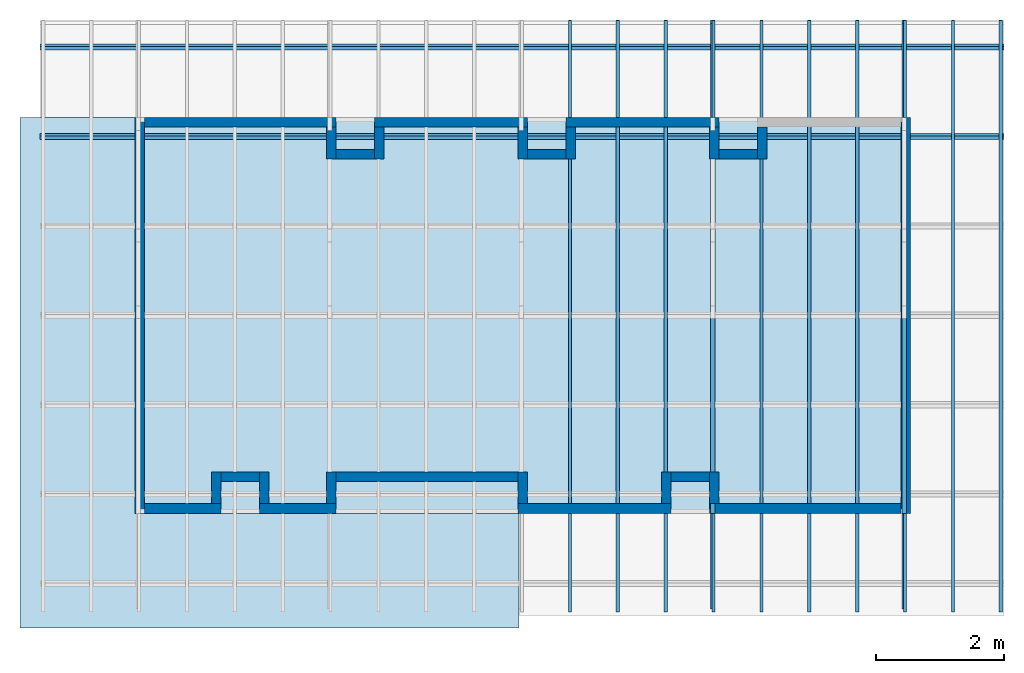
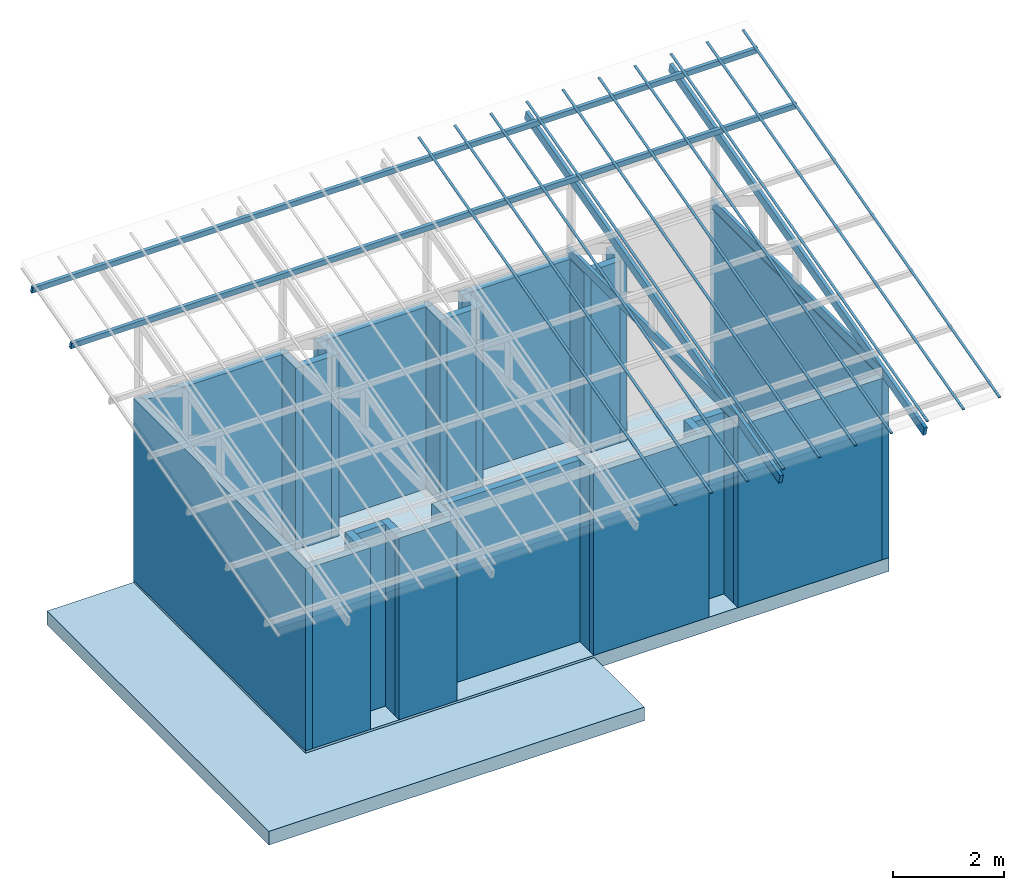
# One storey, part 2 of 4: 27 walls, 16 beams, 2 slabs.
"""IFC4 building model written with IfcOpenShell, lengths in metres."""

from ifc_helpers import new_model, entity, si_unit, converted_unit, frame, origin_with_axes, origin_2d_with_axis, place, context, subcontext, project, spatial, line, indexed_curve, rectangle, outline, extrude, material, layer, layer_set, layer_usage, material_profile, profile_set, profile_usage, type_object, element, save


model = new_model("IFC4")

# Units and contexts
model_context = context("Model", 3, precision=1e-05, world=origin_with_axes())
plan_context = context("Plan", 2, precision=1e-05, world=origin_2d_with_axis())
body_context = subcontext(model_context, "Body", "Model", "MODEL_VIEW")
ifc_project = project(units=[si_unit("VOLUMEUNIT", "CUBIC_METRE"), si_unit("LENGTHUNIT", "METRE"), converted_unit("PLANEANGLEUNIT", "degree", entity("IfcReal", 0.0174532925199433), si_unit("PLANEANGLEUNIT", "RADIAN"), dimensions=[0, 0, 0, 0, 0, 0, 0]), si_unit("AREAUNIT", "SQUARE_METRE")], contexts=[model_context, plan_context])

# Site, building, storey
site_placement = place(None, origin_with_axes())
site = spatial("IfcSite", under=ifc_project, at=site_placement)
building_placement = place(site_placement, origin_with_axes())
building = spatial("IfcBuilding", under=site, at=building_placement, Name="Building")
storey_placement = place(building_placement, origin_with_axes())
storey = spatial("IfcBuildingStorey", under=building, at=storey_placement, Name="Storey")

# Beams
ifc_material_1 = material()
ifc_material_profile_1 = material_profile(ifc_material_1, rectangle(XDim=0.0700000002980232, YDim=0.200000002980232))
ifc_profile_set_1 = profile_set([ifc_material_profile_1])
ifc_profile_usage_1 = profile_usage(ifc_profile_set_1, cardinal=2)
beam_type_1 = type_object("IfcBeamType", PredefinedType="BEAM", material=ifc_profile_set_1)
beam_1_placement = place(storey_placement, frame((9.05000114440918, 6.19999980926514, 4.00000095367432), z_axis=(-1.19209303761636e-07, -1.0, -1.62920684942947e-07), x_axis=(1.0, -1.19209317972491e-07, 4.37113918394516e-08)))
element("IfcBeam", 1, at=beam_1_placement, inside=storey, type_object=beam_type_1, material=ifc_profile_usage_1, Name="Beam", PredefinedType="NOTDEFINED", context=body_context, shape_type="SweptSolid", body=[
    extrude(rectangle(XDim=0.0700000002980232, YDim=0.200000002980232), frame((0.0, 0.100000001490116, 0.0), z_axis=(0.0, 0.0, 1.0), x_axis=(1.0, 0.0, 0.0)), (0.0, 0.0, 1.0), 6.19999988925087),
])
ifc_profile_usage_2 = profile_usage(ifc_profile_set_1, cardinal=2)
beam_2_placement = place(storey_placement, frame((12.0500011444092, 6.19999980926514, 4.00000095367432), z_axis=(-1.19209303761636e-07, -1.0, -1.62920684942947e-07), x_axis=(1.0, -1.19209317972491e-07, 4.37113918394516e-08)))
element("IfcBeam", 2, at=beam_2_placement, inside=storey, type_object=beam_type_1, material=ifc_profile_usage_2, Name="Beam", PredefinedType="NOTDEFINED", context=body_context, shape_type="SweptSolid", body=[
    extrude(rectangle(XDim=0.0700000002980232, YDim=0.200000002980232), frame((0.0, 0.100000001490116, 0.0), z_axis=(0.0, 0.0, 1.0), x_axis=(1.0, 0.0, 0.0)), (0.0, 0.0, 1.0), 6.19999988925087),
])
ifc_profile_usage_3 = profile_usage(ifc_profile_set_1, cardinal=2)
beam_3_placement = place(storey_placement, frame((9.05000114440918, -1.44888913631439, 3.61177134513855), z_axis=(1.6689341464371e-07, 0.965925753116608, 0.258819311857224), x_axis=(-1.0, 1.50995802528087e-07, 8.13025877732798e-08)))
element("IfcBeam", 3, at=beam_3_placement, inside=storey, type_object=beam_type_1, material=ifc_profile_usage_3, Name="Beam", PredefinedType="NOTDEFINED", context=body_context, shape_type="SweptSolid", body=[
    extrude(rectangle(XDim=0.0700000002980232, YDim=0.200000002980232), frame((0.0, 0.100000001490116, 0.0), z_axis=(0.0, 0.0, 1.0), x_axis=(1.0, 0.0, 0.0)), (0.0, 0.0, 1.0), 9.49999957335641),
])
ifc_profile_usage_4 = profile_usage(ifc_profile_set_1, cardinal=2)
beam_4_placement = place(storey_placement, frame((12.0500011444092, -1.44888913631439, 3.61177134513855), z_axis=(1.6689341464371e-07, 0.965925753116608, 0.258819311857224), x_axis=(-1.0, 1.50995802528087e-07, 8.13025877732798e-08)))
element("IfcBeam", 4, at=beam_4_placement, inside=storey, type_object=beam_type_1, material=ifc_profile_usage_4, Name="Beam", PredefinedType="NOTDEFINED", context=body_context, shape_type="SweptSolid", body=[
    extrude(rectangle(XDim=0.0700000002980232, YDim=0.200000002980232), frame((0.0, 0.100000001490116, 0.0), z_axis=(0.0, 0.0, 1.0), x_axis=(1.0, 0.0, 0.0)), (0.0, 0.0, 1.0), 9.49999957335641),
])
ifc_material_profile_2 = material_profile(ifc_material_1, rectangle(XDim=0.0599999986588955, YDim=0.150000005960464))
ifc_profile_set_2 = profile_set([ifc_material_profile_2])
ifc_profile_usage_5 = profile_usage(ifc_profile_set_2, cardinal=2)
beam_type_2 = type_object("IfcBeamType", Name="Caibro", PredefinedType="BEAM", material=ifc_profile_set_2)
beam_5_placement = place(storey_placement, frame((-1.48500049114227, 5.92248487472534, 5.79398727416992), z_axis=(1.0, 1.74234060068557e-07, -4.22219486040376e-08), x_axis=(-1.57369242970162e-07, 0.965925514698029, 0.258819907903671)))
element("IfcBeam", 5, at=beam_5_placement, inside=storey, type_object=beam_type_2, material=ifc_profile_usage_5, Name="Beam", PredefinedType="NOTDEFINED", context=body_context, shape_type="SweptSolid", body=[
    extrude(rectangle(XDim=0.0599999986588955, YDim=0.150000005960464), frame((0.0, 0.075000002980232, 0.0), z_axis=(0.0, 0.0, 1.0), x_axis=(1.0, 0.0, 0.0)), (0.0, 0.0, 1.0), 15.1000003233656),
])
ifc_profile_usage_6 = profile_usage(ifc_profile_set_2, cardinal=2)
beam_6_placement = place(storey_placement, frame((-1.48500061035156, 7.32307767868042, 6.16927623748779), z_axis=(1.0, 1.74234060068557e-07, -4.22219486040376e-08), x_axis=(-1.57369242970162e-07, 0.965925514698029, 0.258819907903671)))
element("IfcBeam", 6, at=beam_6_placement, inside=storey, type_object=beam_type_2, material=ifc_profile_usage_6, Name="Beam", PredefinedType="NOTDEFINED", context=body_context, shape_type="SweptSolid", body=[
    extrude(rectangle(XDim=0.0599999986588955, YDim=0.150000005960464), frame((0.0, 0.075000002980232, 0.0), z_axis=(0.0, 0.0, 1.0), x_axis=(1.0, 0.0, 0.0)), (0.0, 0.0, 1.0), 15.1000003233656),
])
ifc_material_profile_3 = material_profile(ifc_material_1, rectangle(XDim=0.0500000007450581, YDim=0.0199999995529652))
ifc_profile_set_3 = profile_set([ifc_material_profile_3])
ifc_profile_usage_7 = profile_usage(ifc_profile_set_3, cardinal=2)
beam_type_3 = type_object("IfcBeamType", PredefinedType="BEAM", material=ifc_profile_set_3)
beam_7_placement = place(storey_placement, frame((6.81500005722046, -1.53888702392578, 3.95000076293945), z_axis=(-1.05647404780029e-06, 0.965925574302673, 0.258819997310638), x_axis=(-1.0, -1.10467010472348e-06, 4.078152215925e-08)))
element("IfcBeam", 7, at=beam_7_placement, inside=storey, type_object=beam_type_3, material=ifc_profile_usage_7, Name="Beam", PredefinedType="NOTDEFINED", context=body_context, shape_type="SweptSolid", body=[
    extrude(rectangle(XDim=0.0500000007450581, YDim=0.0199999995529652), frame((0.0, 0.0099999997764826, 0.0), z_axis=(0.0, 0.0, 1.0), x_axis=(1.0, 0.0, 0.0)), (0.0, 0.0, 1.0), 9.5898903404752),
])
ifc_profile_usage_8 = profile_usage(ifc_profile_set_3, cardinal=2)
beam_8_placement = place(storey_placement, frame((7.56500005722046, -1.53888702392578, 3.95000076293945), z_axis=(-1.05647404780029e-06, 0.965925574302673, 0.258819997310638), x_axis=(-1.0, -1.10467010472348e-06, 4.078152215925e-08)))
element("IfcBeam", 8, at=beam_8_placement, inside=storey, type_object=beam_type_3, material=ifc_profile_usage_8, Name="Beam", PredefinedType="NOTDEFINED", context=body_context, shape_type="SweptSolid", body=[
    extrude(rectangle(XDim=0.0500000007450581, YDim=0.0199999995529652), frame((0.0, 0.0099999997764826, 0.0), z_axis=(0.0, 0.0, 1.0), x_axis=(1.0, 0.0, 0.0)), (0.0, 0.0, 1.0), 9.5898903404752),
])
ifc_profile_usage_9 = profile_usage(ifc_profile_set_3, cardinal=2)
beam_9_placement = place(storey_placement, frame((8.3149995803833, -1.53888702392578, 3.95000076293945), z_axis=(-1.05647404780029e-06, 0.965925574302673, 0.258819997310638), x_axis=(-1.0, -1.10467010472348e-06, 4.078152215925e-08)))
element("IfcBeam", 9, at=beam_9_placement, inside=storey, type_object=beam_type_3, material=ifc_profile_usage_9, Name="Beam", PredefinedType="NOTDEFINED", context=body_context, shape_type="SweptSolid", body=[
    extrude(rectangle(XDim=0.0500000007450581, YDim=0.0199999995529652), frame((0.0, 0.0099999997764826, 0.0), z_axis=(0.0, 0.0, 1.0), x_axis=(1.0, 0.0, 0.0)), (0.0, 0.0, 1.0), 9.5898903404752),
])
ifc_profile_usage_10 = profile_usage(ifc_profile_set_3, cardinal=2)
beam_10_placement = place(storey_placement, frame((9.0649995803833, -1.53888702392578, 3.95000076293945), z_axis=(-1.05647404780029e-06, 0.965925574302673, 0.258819997310638), x_axis=(-1.0, -1.10467010472348e-06, 4.078152215925e-08)))
element("IfcBeam", 10, at=beam_10_placement, inside=storey, type_object=beam_type_3, material=ifc_profile_usage_10, Name="Beam", PredefinedType="NOTDEFINED", context=body_context, shape_type="SweptSolid", body=[
    extrude(rectangle(XDim=0.0500000007450581, YDim=0.0199999995529652), frame((0.0, 0.0099999997764826, 0.0), z_axis=(0.0, 0.0, 1.0), x_axis=(1.0, 0.0, 0.0)), (0.0, 0.0, 1.0), 9.5898903404752),
])
ifc_profile_usage_11 = profile_usage(ifc_profile_set_3, cardinal=2)
beam_11_placement = place(storey_placement, frame((9.8149995803833, -1.53888702392578, 3.95000076293945), z_axis=(-1.05647404780029e-06, 0.965925574302673, 0.258819997310638), x_axis=(-1.0, -1.10467010472348e-06, 4.078152215925e-08)))
element("IfcBeam", 11, at=beam_11_placement, inside=storey, type_object=beam_type_3, material=ifc_profile_usage_11, Name="Beam", PredefinedType="NOTDEFINED", context=body_context, shape_type="SweptSolid", body=[
    extrude(rectangle(XDim=0.0500000007450581, YDim=0.0199999995529652), frame((0.0, 0.0099999997764826, 0.0), z_axis=(0.0, 0.0, 1.0), x_axis=(1.0, 0.0, 0.0)), (0.0, 0.0, 1.0), 9.5898903404752),
])
ifc_profile_usage_12 = profile_usage(ifc_profile_set_3, cardinal=2)
beam_12_placement = place(storey_placement, frame((10.5649995803833, -1.53888702392578, 3.95000076293945), z_axis=(-1.05647404780029e-06, 0.965925574302673, 0.258819997310638), x_axis=(-1.0, -1.10467010472348e-06, 4.078152215925e-08)))
element("IfcBeam", 12, at=beam_12_placement, inside=storey, type_object=beam_type_3, material=ifc_profile_usage_12, Name="Beam", PredefinedType="NOTDEFINED", context=body_context, shape_type="SweptSolid", body=[
    extrude(rectangle(XDim=0.0500000007450581, YDim=0.0199999995529652), frame((0.0, 0.0099999997764826, 0.0), z_axis=(0.0, 0.0, 1.0), x_axis=(1.0, 0.0, 0.0)), (0.0, 0.0, 1.0), 9.5898903404752),
])
ifc_profile_usage_13 = profile_usage(ifc_profile_set_3, cardinal=2)
beam_13_placement = place(storey_placement, frame((11.3149995803833, -1.53888702392578, 3.95000076293945), z_axis=(-1.05647404780029e-06, 0.965925574302673, 0.258819997310638), x_axis=(-1.0, -1.10467010472348e-06, 4.078152215925e-08)))
element("IfcBeam", 13, at=beam_13_placement, inside=storey, type_object=beam_type_3, material=ifc_profile_usage_13, Name="Beam", PredefinedType="NOTDEFINED", context=body_context, shape_type="SweptSolid", body=[
    extrude(rectangle(XDim=0.0500000007450581, YDim=0.0199999995529652), frame((0.0, 0.0099999997764826, 0.0), z_axis=(0.0, 0.0, 1.0), x_axis=(1.0, 0.0, 0.0)), (0.0, 0.0, 1.0), 9.5898903404752),
])
ifc_profile_usage_14 = profile_usage(ifc_profile_set_3, cardinal=2)
beam_14_placement = place(storey_placement, frame((12.0649995803833, -1.53888702392578, 3.95000076293945), z_axis=(-1.05647404780029e-06, 0.965925574302673, 0.258819997310638), x_axis=(-1.0, -1.10467010472348e-06, 4.078152215925e-08)))
element("IfcBeam", 14, at=beam_14_placement, inside=storey, type_object=beam_type_3, material=ifc_profile_usage_14, Name="Beam", PredefinedType="NOTDEFINED", context=body_context, shape_type="SweptSolid", body=[
    extrude(rectangle(XDim=0.0500000007450581, YDim=0.0199999995529652), frame((0.0, 0.0099999997764826, 0.0), z_axis=(0.0, 0.0, 1.0), x_axis=(1.0, 0.0, 0.0)), (0.0, 0.0, 1.0), 9.5898903404752),
])
ifc_profile_usage_15 = profile_usage(ifc_profile_set_3, cardinal=2)
beam_15_placement = place(storey_placement, frame((12.8149995803833, -1.53888702392578, 3.95000076293945), z_axis=(-1.05647404780029e-06, 0.965925574302673, 0.258819997310638), x_axis=(-1.0, -1.10467010472348e-06, 4.078152215925e-08)))
element("IfcBeam", 15, at=beam_15_placement, inside=storey, type_object=beam_type_3, material=ifc_profile_usage_15, Name="Beam", PredefinedType="NOTDEFINED", context=body_context, shape_type="SweptSolid", body=[
    extrude(rectangle(XDim=0.0500000007450581, YDim=0.0199999995529652), frame((0.0, 0.0099999997764826, 0.0), z_axis=(0.0, 0.0, 1.0), x_axis=(1.0, 0.0, 0.0)), (0.0, 0.0, 1.0), 9.5898903404752),
])
ifc_profile_usage_16 = profile_usage(ifc_profile_set_3, cardinal=2)
beam_16_placement = place(storey_placement, frame((13.5649995803833, -1.53888702392578, 3.95000076293945), z_axis=(-1.05647404780029e-06, 0.965925574302673, 0.258819997310638), x_axis=(-1.0, -1.10467010472348e-06, 4.078152215925e-08)))
element("IfcBeam", 16, at=beam_16_placement, inside=storey, type_object=beam_type_3, material=ifc_profile_usage_16, Name="Beam", PredefinedType="NOTDEFINED", context=body_context, shape_type="SweptSolid", body=[
    extrude(rectangle(XDim=0.0500000007450581, YDim=0.0199999995529652), frame((0.0, 0.0099999997764826, 0.0), z_axis=(0.0, 0.0, 1.0), x_axis=(1.0, 0.0, 0.0)), (0.0, 0.0, 1.0), 9.5898903404752),
])

# Slabs
ifc_layer_1 = layer(ifc_material_1, 0.3)
ifc_layer_set_1 = layer_set([ifc_layer_1])
ifc_layer_usage_1 = layer_usage(ifc_layer_set_1, "AXIS3", "POSITIVE", 0.0)
slab_type = type_object("IfcSlabType", Name="FLR250", PredefinedType="NOTDEFINED", material=ifc_layer_set_1)
slab_1_placement = place(storey_placement, frame((0.0, 0.0, -0.300000011920929), z_axis=(0.0, 0.0, 1.0), x_axis=(1.0, 0.0, 0.0)))
element("IfcSlab", 17, at=slab_1_placement, inside=storey, type_object=slab_type, material=ifc_layer_usage_1, Name="Slab", PredefinedType="NOTDEFINED", context=body_context, shape_type="SweptSolid", body=[
    extrude(outline(indexed_curve([(5.47549234397593e-07, 0.0), (12.1500015258789, 0.0), (12.1500015258789, 6.19999980926514), (5.47549234397593e-07, 6.19999980926514)], segments=[line(3, 2), line(2, 1), line(1, 4), line(4, 3)], self_intersect=False)), None, (0.0, 0.0, 1.0), 0.3),
])
ifc_layer_usage_2 = layer_usage(ifc_layer_set_1, "AXIS3", "POSITIVE", 0.0)
slab_2_placement = place(storey_placement, frame((0.0, 0.0, -0.350000023841858), z_axis=(0.0, 0.0, 1.0), x_axis=(1.0, 0.0, 0.0)))
element("IfcSlab", 18, at=slab_2_placement, inside=storey, type_object=slab_type, material=ifc_layer_usage_2, Name="Slab", PredefinedType="NOTDEFINED", context=body_context, shape_type="SweptSolid", body=[
    extrude(outline(indexed_curve([(-1.79999995231628, 0.0), (0.0, 0.0), (0.0, 6.19999980926514), (-1.79999995231628, 6.19999980926514), (-1.79999995231628, -1.79999995231628), (0.0, -1.79999995231628), (6.01500082015991, 0.0), (6.01500082015991, -1.79999995231628)], segments=[line(1, 4), line(4, 3), line(3, 2), line(2, 7), line(7, 8), line(8, 6), line(6, 5), line(5, 1)], self_intersect=False)), None, (0.0, 0.0, 1.0), 0.3),
])

# Walls
ifc_material_2 = material(Name="Material")
ifc_layer_2 = layer(ifc_material_2, 0.150000005960464)
ifc_layer_set_2 = layer_set([ifc_layer_2])
ifc_layer_usage_3 = layer_usage(ifc_layer_set_2, "AXIS2", "POSITIVE", 0.0)
wall_type = type_object("IfcWallType", Name="WAL150", PredefinedType="SOLIDWALL", material=ifc_layer_set_2)
wall_1_placement = place(storey_placement, frame((3.15000152587891, 6.19999885559082, 0.0), z_axis=(0.0, 0.0, 1.0), x_axis=(-1.0, 3.89414367418794e-07, 0.0)))
element("IfcWall", 19, at=wall_1_placement, inside=storey, type_object=wall_type, material=ifc_layer_usage_3, Name="Wall", PredefinedType="NOTDEFINED", context=body_context, shape_type="SweptSolid", body=[
    extrude(outline(indexed_curve([(0.0, 0.0), (0.0, 0.150000005960464), (3.00000000000015, 0.150000005960464), (3.00000000000015, 0.0), (0.0, 0.0)], self_intersect=False)), origin_with_axes(), (0.0, 0.0, 1.0), 4.0),
])
ifc_layer_usage_4 = layer_usage(ifc_layer_set_2, "AXIS2", "POSITIVE", 0.0)
wall_2_placement = place(storey_placement, frame((3.00000143051148, 6.04999876022339, 0.0), z_axis=(0.0, 0.0, 1.0), x_axis=(-7.58967132696853e-07, -1.0, 0.0)))
element("IfcWall", 20, at=wall_2_placement, inside=storey, type_object=wall_type, material=ifc_layer_usage_4, Name="Wall", PredefinedType="NOTDEFINED", context=body_context, shape_type="SweptSolid", body=[
    extrude(outline(indexed_curve([(0.0, 0.0), (0.0, 0.150000005960464), (0.500000000000227, 0.150000005960464), (0.500000000000227, 0.0), (0.0, 0.0)], self_intersect=False)), origin_with_axes(), (0.0, 0.0, 1.0), 4.0),
])
ifc_layer_usage_5 = layer_usage(ifc_layer_set_2, "AXIS2", "POSITIVE", 0.0)
wall_3_placement = place(storey_placement, frame((3.15000104904175, 5.54999876022339, 0.0), z_axis=(0.0, 0.0, 1.0), x_axis=(1.0, -7.15255737304688e-07, 0.0)))
element("IfcWall", 21, at=wall_3_placement, inside=storey, type_object=wall_type, material=ifc_layer_usage_5, Name="Wall", PredefinedType="NOTDEFINED", context=body_context, shape_type="SweptSolid", body=[
    extrude(outline(indexed_curve([(0.0, 0.0), (0.0, 0.150000005960464), (0.599999912580037, 0.150000005960464), (0.599999912580037, 0.0), (0.0, 0.0)], self_intersect=False)), origin_with_axes(), (0.0, 0.0, 1.0), 4.0),
])
ifc_layer_usage_6 = layer_usage(ifc_layer_set_2, "AXIS2", "POSITIVE", 0.0)
wall_4_placement = place(storey_placement, frame((3.75000143051148, 6.04999828338623, 0.0), z_axis=(0.0, 0.0, 1.0), x_axis=(-7.58967132696853e-07, -1.0, 0.0)))
element("IfcWall", 22, at=wall_4_placement, inside=storey, type_object=wall_type, material=ifc_layer_usage_6, Name="Wall", PredefinedType="NOTDEFINED", context=body_context, shape_type="SweptSolid", body=[
    extrude(outline(indexed_curve([(0.0, 0.0), (0.0, 0.150000005960464), (0.500000000000227, 0.150000005960464), (0.500000000000227, 0.0), (0.0, 0.0)], self_intersect=False)), origin_with_axes(), (0.0, 0.0, 1.0), 4.0),
])
ifc_layer_usage_7 = layer_usage(ifc_layer_set_2, "AXIS2", "POSITIVE", 0.0)
wall_5_placement = place(storey_placement, frame((3.75000143051148, 6.04999828338623, 0.0), z_axis=(0.0, 0.0, 1.0), x_axis=(1.0, -5.96046447753906e-07, 0.0)))
element("IfcWall", 23, at=wall_5_placement, inside=storey, type_object=wall_type, material=ifc_layer_usage_7, Name="Wall", PredefinedType="NOTDEFINED", context=body_context, shape_type="SweptSolid", body=[
    extrude(outline(indexed_curve([(0.0, 0.0), (0.0, 0.150000005960464), (2.40000004768414, 0.150000005960464), (2.40000004768414, 0.0), (0.0, 0.0)], self_intersect=False)), origin_with_axes(), (0.0, 0.0, 1.0), 4.0),
])
ifc_layer_usage_8 = layer_usage(ifc_layer_set_2, "AXIS2", "POSITIVE", 0.0)
wall_6_placement = place(storey_placement, frame((6.00000143051148, 6.04999685287476, 0.0), z_axis=(0.0, 0.0, 1.0), x_axis=(-7.58967132696853e-07, -1.0, 0.0)))
element("IfcWall", 24, at=wall_6_placement, inside=storey, type_object=wall_type, material=ifc_layer_usage_8, Name="Wall", PredefinedType="NOTDEFINED", context=body_context, shape_type="SweptSolid", body=[
    extrude(outline(indexed_curve([(0.0, 0.0), (0.0, 0.150000005960464), (0.500000000000227, 0.150000005960464), (0.500000000000227, 0.0), (0.0, 0.0)], self_intersect=False)), origin_with_axes(), (0.0, 0.0, 1.0), 4.0),
])
ifc_layer_usage_9 = layer_usage(ifc_layer_set_2, "AXIS2", "POSITIVE", 0.0)
wall_7_placement = place(storey_placement, frame((6.15000104904175, 5.54999685287476, 0.0), z_axis=(0.0, 0.0, 1.0), x_axis=(1.0, -7.15255737304688e-07, 0.0)))
element("IfcWall", 25, at=wall_7_placement, inside=storey, type_object=wall_type, material=ifc_layer_usage_9, Name="Wall", PredefinedType="NOTDEFINED", context=body_context, shape_type="SweptSolid", body=[
    extrude(outline(indexed_curve([(0.0, 0.0), (0.0, 0.150000005960464), (0.599999912580037, 0.150000005960464), (0.599999912580037, 0.0), (0.0, 0.0)], self_intersect=False)), origin_with_axes(), (0.0, 0.0, 1.0), 4.0),
])
ifc_layer_usage_10 = layer_usage(ifc_layer_set_2, "AXIS2", "POSITIVE", 0.0)
wall_8_placement = place(storey_placement, frame((6.75000143051148, 6.0499963760376, 0.0), z_axis=(0.0, 0.0, 1.0), x_axis=(-7.58967132696853e-07, -1.0, 0.0)))
element("IfcWall", 26, at=wall_8_placement, inside=storey, type_object=wall_type, material=ifc_layer_usage_10, Name="Wall", PredefinedType="NOTDEFINED", context=body_context, shape_type="SweptSolid", body=[
    extrude(outline(indexed_curve([(0.0, 0.0), (0.0, 0.150000005960464), (0.500000000000227, 0.150000005960464), (0.500000000000227, 0.0), (0.0, 0.0)], self_intersect=False)), origin_with_axes(), (0.0, 0.0, 1.0), 4.0),
])
ifc_layer_usage_11 = layer_usage(ifc_layer_set_2, "AXIS2", "POSITIVE", 0.0)
wall_9_placement = place(storey_placement, frame((1.55765749987324e-06, 6.19999980926514, 0.0), z_axis=(0.0, 0.0, 1.0), x_axis=(-1.62920684942947e-07, -1.0, 0.0)))
element("IfcWall", 27, at=wall_9_placement, inside=storey, type_object=wall_type, material=ifc_layer_usage_11, Name="Wall", PredefinedType="NOTDEFINED", context=body_context, shape_type="SweptSolid", body=[
    extrude(outline(indexed_curve([(0.0, 0.0), (0.0, 0.150000005960464), (6.19999988925081, 0.150000005960464), (6.19999988925081, 0.0), (0.0, 0.0)], self_intersect=False)), origin_with_axes(), (0.0, 0.0, 1.0), 4.0),
])
ifc_layer_usage_12 = layer_usage(ifc_layer_set_2, "AXIS2", "POSITIVE", 0.0)
wall_10_placement = place(storey_placement, frame((6.75000143051148, 6.0499963760376, 0.0), z_axis=(0.0, 0.0, 1.0), x_axis=(1.0, -5.96046447753906e-07, 0.0)))
element("IfcWall", 28, at=wall_10_placement, inside=storey, type_object=wall_type, material=ifc_layer_usage_12, Name="Wall", PredefinedType="NOTDEFINED", context=body_context, shape_type="SweptSolid", body=[
    extrude(outline(indexed_curve([(0.0, 0.0), (0.0, 0.150000005960464), (2.40000004768414, 0.150000005960464), (2.40000004768414, 0.0), (0.0, 0.0)], self_intersect=False)), origin_with_axes(), (0.0, 0.0, 1.0), 4.0),
])
ifc_layer_usage_13 = layer_usage(ifc_layer_set_2, "AXIS2", "POSITIVE", 0.0)
wall_11_placement = place(storey_placement, frame((9.00000190734864, 6.04999685287476, 0.0), z_axis=(0.0, 0.0, 1.0), x_axis=(-7.58967132696853e-07, -1.0, 0.0)))
element("IfcWall", 29, at=wall_11_placement, inside=storey, type_object=wall_type, material=ifc_layer_usage_13, Name="Wall", PredefinedType="NOTDEFINED", context=body_context, shape_type="SweptSolid", body=[
    extrude(outline(indexed_curve([(0.0, 0.0), (0.0, 0.150000005960464), (0.5, 0.150000005960464), (0.5, 0.0), (0.0, 0.0)], self_intersect=False)), origin_with_axes(), (0.0, 0.0, 1.0), 4.0),
])
ifc_layer_usage_14 = layer_usage(ifc_layer_set_2, "AXIS2", "POSITIVE", 0.0)
wall_12_placement = place(storey_placement, frame((9.15000152587891, 5.54999685287476, 0.0), z_axis=(0.0, 0.0, 1.0), x_axis=(1.0, -7.15255737304688e-07, 0.0)))
element("IfcWall", 30, at=wall_12_placement, inside=storey, type_object=wall_type, material=ifc_layer_usage_14, Name="Wall", PredefinedType="NOTDEFINED", context=body_context, shape_type="SweptSolid", body=[
    extrude(outline(indexed_curve([(0.0, 0.0), (0.0, 0.150000005960464), (0.600000384450025, 0.150000005960464), (0.600000384450025, 0.0), (0.0, 0.0)], self_intersect=False)), origin_with_axes(), (0.0, 0.0, 1.0), 4.0),
])
ifc_layer_usage_15 = layer_usage(ifc_layer_set_2, "AXIS2", "POSITIVE", 0.0)
wall_13_placement = place(storey_placement, frame((9.75000190734864, 6.0499963760376, 0.0), z_axis=(0.0, 0.0, 1.0), x_axis=(-7.58967132696853e-07, -1.0, 0.0)))
element("IfcWall", 31, at=wall_13_placement, inside=storey, type_object=wall_type, material=ifc_layer_usage_15, Name="Wall", PredefinedType="NOTDEFINED", context=body_context, shape_type="SweptSolid", body=[
    extrude(outline(indexed_curve([(0.0, 0.0), (0.0, 0.150000005960464), (0.5, 0.150000005960464), (0.5, 0.0), (0.0, 0.0)], self_intersect=False)), origin_with_axes(), (0.0, 0.0, 1.0), 4.0),
])
ifc_layer_usage_16 = layer_usage(ifc_layer_set_2, "AXIS2", "POSITIVE", 0.0)
wall_14_placement = place(storey_placement, frame((12.0000019073486, 6.19999980926514, 0.0), z_axis=(0.0, 0.0, 1.0), x_axis=(-1.62920684942947e-07, -1.0, 0.0)))
element("IfcWall", 32, at=wall_14_placement, inside=storey, type_object=wall_type, material=ifc_layer_usage_16, Name="Wall", PredefinedType="NOTDEFINED", context=body_context, shape_type="SweptSolid", body=[
    extrude(outline(indexed_curve([(0.0, 0.0), (0.0, 0.150000005960464), (6.1999998892508, 0.150000005960464), (6.1999998892508, 0.0), (0.0, 0.0)], self_intersect=False)), origin_with_axes(), (0.0, 0.0, 1.0), 4.0),
])
ifc_layer_usage_17 = layer_usage(ifc_layer_set_2, "AXIS2", "POSITIVE", 0.0)
wall_15_placement = place(storey_placement, frame((9.00000095367432, 1.16824310225638e-06, 0.0), z_axis=(0.0, 0.0, 1.0), x_axis=(1.0, -4.76837158203125e-07, 0.0)))
element("IfcWall", 33, at=wall_15_placement, inside=storey, type_object=wall_type, material=ifc_layer_usage_17, Name="Wall", PredefinedType="NOTDEFINED", context=body_context, shape_type="SweptSolid", body=[
    extrude(outline(indexed_curve([(0.0, 0.0), (0.0, 0.150000005960464), (3.00000000000034, 0.150000005960464), (3.00000000000034, 0.0), (0.0, 0.0)], self_intersect=False)), origin_with_axes(), (0.0, 0.0, 1.0), 4.0),
])
ifc_layer_usage_18 = layer_usage(ifc_layer_set_2, "AXIS2", "POSITIVE", 0.0)
wall_16_placement = place(storey_placement, frame((9.00000095367432, 0.65000104904175, 0.0), z_axis=(0.0, 0.0, 1.0), x_axis=(-7.58967132696853e-07, -1.0, 0.0)))
element("IfcWall", 34, at=wall_16_placement, inside=storey, type_object=wall_type, material=ifc_layer_usage_18, Name="Wall", PredefinedType="NOTDEFINED", context=body_context, shape_type="SweptSolid", body=[
    extrude(outline(indexed_curve([(0.0, 0.0), (0.0, 0.150000005960464), (0.5, 0.150000005960464), (0.5, 0.0), (0.0, 0.0)], self_intersect=False)), origin_with_axes(), (0.0, 0.0, 1.0), 4.0),
])
ifc_layer_usage_19 = layer_usage(ifc_layer_set_2, "AXIS2", "POSITIVE", 0.0)
wall_17_placement = place(storey_placement, frame((9.00000190734863, 0.650001049041748, 0.0), z_axis=(0.0, 0.0, 1.0), x_axis=(-1.0, 8.66251525621919e-07, 0.0)))
element("IfcWall", 35, at=wall_17_placement, inside=storey, type_object=wall_type, material=ifc_layer_usage_19, Name="Wall", PredefinedType="NOTDEFINED", context=body_context, shape_type="SweptSolid", body=[
    extrude(outline(indexed_curve([(0.0, 0.0), (0.0, 0.150000005960464), (0.600000384450075, 0.150000005960464), (0.600000384450075, 0.0), (0.0, 0.0)], self_intersect=False)), origin_with_axes(), (0.0, 0.0, 1.0), 4.0),
])
ifc_layer_usage_20 = layer_usage(ifc_layer_set_2, "AXIS2", "POSITIVE", 0.0)
wall_18_placement = place(storey_placement, frame((8.25000190734864, 0.65000104904175, 0.0), z_axis=(0.0, 0.0, 1.0), x_axis=(-7.58967132696853e-07, -1.0, 0.0)))
element("IfcWall", 36, at=wall_18_placement, inside=storey, type_object=wall_type, material=ifc_layer_usage_20, Name="Wall", PredefinedType="NOTDEFINED", context=body_context, shape_type="SweptSolid", body=[
    extrude(outline(indexed_curve([(0.0, 0.0), (0.0, 0.150000005960464), (0.5, 0.150000005960464), (0.5, 0.0), (0.0, 0.0)], self_intersect=False)), origin_with_axes(), (0.0, 0.0, 1.0), 4.0),
])
ifc_layer_usage_21 = layer_usage(ifc_layer_set_2, "AXIS2", "POSITIVE", 0.0)
wall_19_placement = place(storey_placement, frame((6.00000143051148, 2.3543834699602e-06, 0.0), z_axis=(0.0, 0.0, 1.0), x_axis=(1.0, -5.96046447753906e-07, 0.0)))
element("IfcWall", 37, at=wall_19_placement, inside=storey, type_object=wall_type, material=ifc_layer_usage_21, Name="Wall", PredefinedType="NOTDEFINED", context=body_context, shape_type="SweptSolid", body=[
    extrude(outline(indexed_curve([(0.0, 0.0), (0.0, 0.150000005960464), (2.40000004768414, 0.150000005960464), (2.40000004768414, 0.0), (0.0, 0.0)], self_intersect=False)), origin_with_axes(), (0.0, 0.0, 1.0), 4.0),
])
ifc_layer_usage_22 = layer_usage(ifc_layer_set_2, "AXIS2", "POSITIVE", 0.0)
wall_20_placement = place(storey_placement, frame((6.00000143051148, 0.65000104904175, 0.0), z_axis=(0.0, 0.0, 1.0), x_axis=(-7.58967132696853e-07, -1.0, 0.0)))
element("IfcWall", 38, at=wall_20_placement, inside=storey, type_object=wall_type, material=ifc_layer_usage_22, Name="Wall", PredefinedType="NOTDEFINED", context=body_context, shape_type="SweptSolid", body=[
    extrude(outline(indexed_curve([(0.0, 0.0), (0.0, 0.150000005960464), (0.500000000000227, 0.150000005960464), (0.500000000000227, 0.0), (0.0, 0.0)], self_intersect=False)), origin_with_axes(), (0.0, 0.0, 1.0), 4.0),
])
ifc_layer_usage_23 = layer_usage(ifc_layer_set_2, "AXIS2", "POSITIVE", 0.0)
wall_21_placement = place(storey_placement, frame((6.00000143051148, 0.65000104904175, 0.0), z_axis=(0.0, 0.0, 1.0), x_axis=(-1.0, 3.89414367418794e-07, 0.0)))
element("IfcWall", 39, at=wall_21_placement, inside=storey, type_object=wall_type, material=ifc_layer_usage_23, Name="Wall", PredefinedType="NOTDEFINED", context=body_context, shape_type="SweptSolid", body=[
    extrude(outline(indexed_curve([(0.0, 0.0), (0.0, 0.150000005960464), (2.8499999063059, 0.150000005960464), (2.8499999063059, 0.0), (0.0, 0.0)], self_intersect=False)), origin_with_axes(), (0.0, 0.0, 1.0), 4.0),
])
ifc_layer_usage_24 = layer_usage(ifc_layer_set_2, "AXIS2", "POSITIVE", 0.0)
wall_22_placement = place(storey_placement, frame((3.00000143051148, 0.65000104904175, 0.0), z_axis=(0.0, 0.0, 1.0), x_axis=(-7.58967132696853e-07, -1.0, 0.0)))
element("IfcWall", 40, at=wall_22_placement, inside=storey, type_object=wall_type, material=ifc_layer_usage_24, Name="Wall", PredefinedType="NOTDEFINED", context=body_context, shape_type="SweptSolid", body=[
    extrude(outline(indexed_curve([(0.0, 0.0), (0.0, 0.150000005960464), (0.500000000000227, 0.150000005960464), (0.500000000000227, 0.0), (0.0, 0.0)], self_intersect=False)), origin_with_axes(), (0.0, 0.0, 1.0), 4.0),
])
ifc_layer_usage_25 = layer_usage(ifc_layer_set_2, "AXIS2", "POSITIVE", 0.0)
wall_23_placement = place(storey_placement, frame((3.15000104904175, 0.15000092983246, 0.0), z_axis=(0.0, 0.0, 1.0), x_axis=(-1.0, 3.89414367418794e-07, 0.0)))
element("IfcWall", 41, at=wall_23_placement, inside=storey, type_object=wall_type, material=ifc_layer_usage_25, Name="Wall", PredefinedType="NOTDEFINED", context=body_context, shape_type="SweptSolid", body=[
    extrude(outline(indexed_curve([(0.0, 0.0), (0.0, 0.150000005960464), (1.20000002384195, 0.150000005960464), (1.20000002384195, 0.0), (0.0, 0.0)], self_intersect=False)), origin_with_axes(), (0.0, 0.0, 1.0), 4.0),
])
ifc_layer_usage_26 = layer_usage(ifc_layer_set_2, "AXIS2", "POSITIVE", 0.0)
wall_24_placement = place(storey_placement, frame((1.95000147819519, 0.65000104904175, 0.0), z_axis=(0.0, 0.0, 1.0), x_axis=(-7.58967132696853e-07, -1.0, 0.0)))
element("IfcWall", 42, at=wall_24_placement, inside=storey, type_object=wall_type, material=ifc_layer_usage_26, Name="Wall", PredefinedType="NOTDEFINED", context=body_context, shape_type="SweptSolid", body=[
    extrude(outline(indexed_curve([(0.0, 0.0), (0.0, 0.150000005960464), (0.500000000000128, 0.150000005960464), (0.500000000000128, 0.0), (0.0, 0.0)], self_intersect=False)), origin_with_axes(), (0.0, 0.0, 1.0), 4.0),
])
ifc_layer_usage_27 = layer_usage(ifc_layer_set_2, "AXIS2", "POSITIVE", 0.0)
wall_25_placement = place(storey_placement, frame((1.95000243186951, 0.650001049041748, 0.0), z_axis=(0.0, 0.0, 1.0), x_axis=(-1.0, 8.66251525621919e-07, 0.0)))
element("IfcWall", 43, at=wall_25_placement, inside=storey, type_object=wall_type, material=ifc_layer_usage_27, Name="Wall", PredefinedType="NOTDEFINED", context=body_context, shape_type="SweptSolid", body=[
    extrude(outline(indexed_curve([(0.0, 0.0), (0.0, 0.150000005960464), (0.600000384450075, 0.150000005960464), (0.600000384450075, 0.0), (0.0, 0.0)], self_intersect=False)), origin_with_axes(), (0.0, 0.0, 1.0), 4.0),
])
ifc_layer_usage_28 = layer_usage(ifc_layer_set_2, "AXIS2", "POSITIVE", 0.0)
wall_26_placement = place(storey_placement, frame((1.20000243186951, 0.65000104904175, 0.0), z_axis=(0.0, 0.0, 1.0), x_axis=(-7.58967132696853e-07, -1.0, 0.0)))
element("IfcWall", 44, at=wall_26_placement, inside=storey, type_object=wall_type, material=ifc_layer_usage_28, Name="Wall", PredefinedType="NOTDEFINED", context=body_context, shape_type="SweptSolid", body=[
    extrude(outline(indexed_curve([(0.0, 0.0), (0.0, 0.150000005960464), (0.500000000000128, 0.150000005960464), (0.500000000000128, 0.0), (0.0, 0.0)], self_intersect=False)), origin_with_axes(), (0.0, 0.0, 1.0), 4.0),
])
ifc_layer_usage_29 = layer_usage(ifc_layer_set_2, "AXIS2", "POSITIVE", 0.0)
wall_27_placement = place(storey_placement, frame((1.35000205039978, 0.15000092983246, 0.0), z_axis=(0.0, 0.0, 1.0), x_axis=(-1.0, 3.89414367418794e-07, 0.0)))
element("IfcWall", 45, at=wall_27_placement, inside=storey, type_object=wall_type, material=ifc_layer_usage_29, Name="Wall", PredefinedType="NOTDEFINED", context=body_context, shape_type="SweptSolid", body=[
    extrude(outline(indexed_curve([(0.0, 0.0), (0.0, 0.150000005960464), (1.20000002384195, 0.150000005960464), (1.20000002384195, 0.0), (0.0, 0.0)], self_intersect=False)), origin_with_axes(), (0.0, 0.0, 1.0), 4.0),
])

save(model, "model.ifc")
